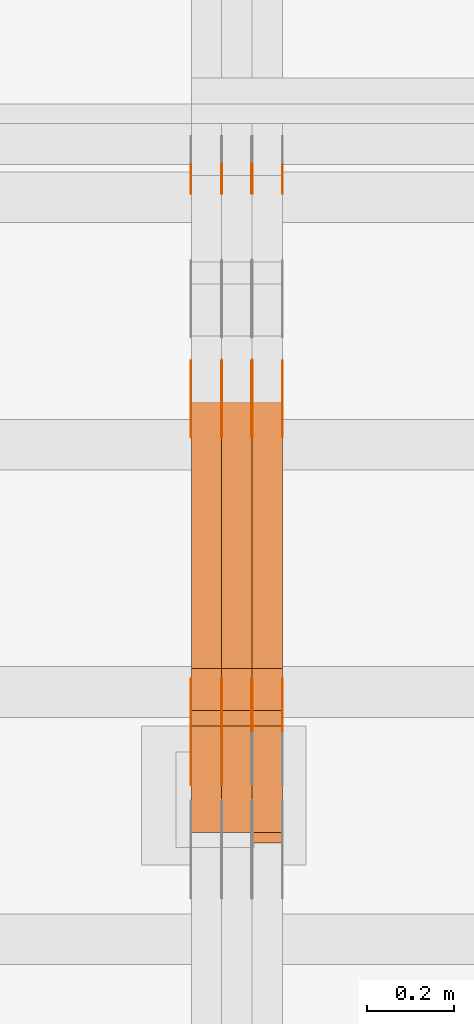
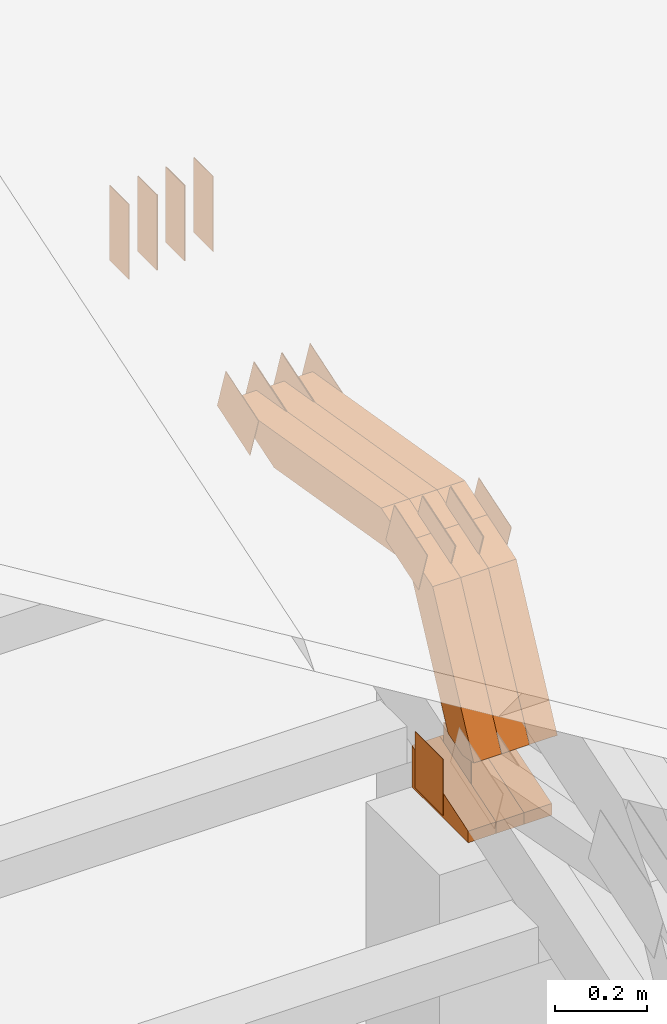
# One storey, part 278 of 385: 29 proxies.
"""IFC2X3 building model written with IfcOpenShell, lengths in millimetres."""

from ifc_helpers import new_model, entity, si_unit, converted_unit, derived_unit, direction, frame, frame_2d, origin, place, context, subcontext, project, spatial, polyline, rectangle, outline, extrude, source, transform, mapped, material, type_object, type_shapes, element, save


model = new_model("IFC2X3")

# Units and contexts
model_context = context("Model", 3, precision=0.01, world=origin(), true_north=direction((6.12303176911189e-17, 1.0)))
body_context = subcontext(model_context, "Body", "Model", "MODEL_VIEW")
ifc_project = project(units=[si_unit("LENGTHUNIT", "METRE", prefix="MILLI"), si_unit("AREAUNIT", "SQUARE_METRE"), si_unit("VOLUMEUNIT", "CUBIC_METRE"), converted_unit("PLANEANGLEUNIT", "DEGREE", entity("IfcRatioMeasure", 0.0174532925199433), si_unit("PLANEANGLEUNIT", "RADIAN"), dimensions=[0, 0, 0, 0, 0, 0, 0]), si_unit("MASSUNIT", "GRAM", prefix="KILO"), derived_unit("MASSDENSITYUNIT", [(si_unit("MASSUNIT", "GRAM", prefix="KILO"), 1), (si_unit("LENGTHUNIT", "METRE"), -3)]), si_unit("TIMEUNIT", "SECOND"), si_unit("FREQUENCYUNIT", "HERTZ"), si_unit("THERMODYNAMICTEMPERATUREUNIT", "DEGREE_CELSIUS"), derived_unit("THERMALTRANSMITTANCEUNIT", [(si_unit("MASSUNIT", "GRAM", prefix="KILO"), 1), (si_unit("THERMODYNAMICTEMPERATUREUNIT", "KELVIN"), -1), (si_unit("TIMEUNIT", "SECOND"), -3)]), derived_unit("VOLUMETRICFLOWRATEUNIT", [(si_unit("LENGTHUNIT", "METRE"), 3), (si_unit("TIMEUNIT", "SECOND"), -1)]), si_unit("ELECTRICCURRENTUNIT", "AMPERE"), si_unit("ELECTRICVOLTAGEUNIT", "VOLT"), si_unit("POWERUNIT", "WATT"), si_unit("FORCEUNIT", "NEWTON", prefix="KILO"), si_unit("ILLUMINANCEUNIT", "LUX"), si_unit("LUMINOUSFLUXUNIT", "LUMEN"), si_unit("LUMINOUSINTENSITYUNIT", "CANDELA"), derived_unit("USERDEFINED", [(si_unit("MASSUNIT", "GRAM", prefix="KILO"), -1), (si_unit("LENGTHUNIT", "METRE"), -2), (si_unit("TIMEUNIT", "SECOND"), 3), (si_unit("LUMINOUSFLUXUNIT", "LUMEN"), 1)]), derived_unit("LINEARVELOCITYUNIT", [(si_unit("LENGTHUNIT", "METRE"), 1), (si_unit("TIMEUNIT", "SECOND"), -1)]), si_unit("PRESSUREUNIT", "PASCAL"), derived_unit("USERDEFINED", [(si_unit("LENGTHUNIT", "METRE"), -2), (si_unit("MASSUNIT", "GRAM", prefix="KILO"), 1), (si_unit("TIMEUNIT", "SECOND"), -2)])], contexts=[model_context])

# Site, building, storey
site_placement = place(None, origin())
site = spatial("IfcSite", under=ifc_project, at=site_placement, CompositionType="ELEMENT")
building_placement = place(site_placement, origin())
building = spatial("IfcBuilding", under=site, at=building_placement, CompositionType="ELEMENT")
storey_placement = place(building_placement, origin())
storey = spatial("IfcBuildingStorey", under=building, at=storey_placement, Name="Default", CompositionType="ELEMENT", Elevation=0.0)

# Proxies
ifc_material_1 = material(Name="IfcSurfaceStyle #415732")
building_element_proxy_type_1 = type_object("IfcBuildingElementProxyType", PredefinedType="NOTDEFINED", material=ifc_material_1)
shared_shape_1 = source(origin(), body_context, "Body", "SweptSolid", [
    extrude(rectangle(XDim=200.0, YDim=84.0, at=frame_2d((0.0, -7.105427357601e-15), x_axis=(1.0, 0.0))), frame((100.0, 42.0, 0.0), z_axis=(0.0, 0.0, 1.0), x_axis=(-1.0, 0.0, 0.0)), (0.0, 0.0, 1.0), 1.3),
])
type_shapes(building_element_proxy_type_1, [shared_shape_1])
proxy_1_placement = place(building_placement, frame((33386.3, 13702.0, 3651.4150390625), z_axis=(-1.0, 0.0, 0.0), x_axis=(0.0, 0.0, -1.0)))
element("IfcBuildingElementProxy", 1, at=proxy_1_placement, inside=storey, type_object=building_element_proxy_type_1, material=ifc_material_1, context=body_context, shape_type="MappedRepresentation", body=[
    mapped(shared_shape_1, transform((0.0, 0.0, 0.0), scale=1.0)),
])
ifc_material_2 = material(Name="IfcSurfaceStyle #415675")
building_element_proxy_type_2 = type_object("IfcBuildingElementProxyType", PredefinedType="NOTDEFINED", material=ifc_material_2)
shared_shape_2 = source(origin(), body_context, "Body", "SweptSolid", [
    extrude(rectangle(XDim=200.0, YDim=84.0, at=frame_2d((0.0, -7.105427357601e-15), x_axis=(1.0, 0.0))), frame((100.0, 42.0, 0.0), z_axis=(0.0, 0.0, 1.0), x_axis=(-1.0, 0.0, 0.0)), (0.0, 0.0, 1.0), 1.3),
])
type_shapes(building_element_proxy_type_2, [shared_shape_2])
proxy_2_placement = place(building_placement, frame((33315.0, 13702.0, 3651.4150390625), z_axis=(-1.0, 0.0, 0.0), x_axis=(0.0, 0.0, -1.0)))
element("IfcBuildingElementProxy", 2, at=proxy_2_placement, inside=storey, type_object=building_element_proxy_type_2, material=ifc_material_2, context=body_context, shape_type="MappedRepresentation", body=[
    mapped(shared_shape_2, transform((0.0, 0.0, 0.0), scale=1.0)),
])
ifc_material_3 = material(Name="IfcSurfaceStyle #415618")
building_element_proxy_type_3 = type_object("IfcBuildingElementProxyType", PredefinedType="NOTDEFINED", material=ifc_material_3)
shared_shape_3 = source(origin(), body_context, "Body", "SweptSolid", [
    extrude(rectangle(XDim=200.0, YDim=84.0, at=frame_2d((0.0, -7.105427357601e-15), x_axis=(1.0, 0.0))), frame((100.0, 42.0, 0.0), z_axis=(0.0, 0.0, 1.0), x_axis=(-1.0, 0.0, 0.0)), (0.0, 0.0, 1.0), 1.3),
])
type_shapes(building_element_proxy_type_3, [shared_shape_3])
proxy_3_placement = place(building_placement, frame((33316.3, 13702.0, 3651.4150390625), z_axis=(-1.0, 0.0, 0.0), x_axis=(0.0, 0.0, -1.0)))
element("IfcBuildingElementProxy", 3, at=proxy_3_placement, inside=storey, type_object=building_element_proxy_type_3, material=ifc_material_3, context=body_context, shape_type="MappedRepresentation", body=[
    mapped(shared_shape_3, transform((0.0, 0.0, 0.0), scale=1.0)),
])
ifc_material_4 = material(Name="IfcSurfaceStyle #415561")
building_element_proxy_type_4 = type_object("IfcBuildingElementProxyType", PredefinedType="NOTDEFINED", material=ifc_material_4)
shared_shape_4 = source(origin(), body_context, "Body", "SweptSolid", [
    extrude(rectangle(XDim=200.0, YDim=84.0, at=frame_2d((0.0, -7.105427357601e-15), x_axis=(1.0, 0.0))), frame((100.0, 42.0, 0.0), z_axis=(0.0, 0.0, 1.0), x_axis=(-1.0, 0.0, 0.0)), (0.0, 0.0, 1.0), 1.29999999999998),
])
type_shapes(building_element_proxy_type_4, [shared_shape_4])
proxy_4_placement = place(building_placement, frame((33245.0, 13702.0, 3651.4150390625), z_axis=(-1.0, 0.0, 0.0), x_axis=(0.0, 0.0, -1.0)))
element("IfcBuildingElementProxy", 4, at=proxy_4_placement, inside=storey, type_object=building_element_proxy_type_4, material=ifc_material_4, context=body_context, shape_type="MappedRepresentation", body=[
    mapped(shared_shape_4, transform((0.0, 0.0, 0.0), scale=1.0)),
])
ifc_material_5 = material(Name="IfcSurfaceStyle #415504")
building_element_proxy_type_5 = type_object("IfcBuildingElementProxyType", PredefinedType="NOTDEFINED", material=ifc_material_5)
shared_shape_5 = source(origin(), body_context, "Body", "SweptSolid", [
    extrude(rectangle(XDim=200.0, YDim=84.0, at=frame_2d((0.0, -7.105427357601e-15), x_axis=(1.0, 0.0))), frame((100.0, 42.0, 0.0), z_axis=(0.0, 0.0, 1.0), x_axis=(-1.0, 0.0, 0.0)), (0.0, 0.0, 1.0), 1.29999999999998),
])
type_shapes(building_element_proxy_type_5, [shared_shape_5])
proxy_5_placement = place(building_placement, frame((33246.3, 13702.0, 3651.4150390625), z_axis=(-1.0, 0.0, 0.0), x_axis=(0.0, 0.0, -1.0)))
element("IfcBuildingElementProxy", 5, at=proxy_5_placement, inside=storey, type_object=building_element_proxy_type_5, material=ifc_material_5, context=body_context, shape_type="MappedRepresentation", body=[
    mapped(shared_shape_5, transform((0.0, 0.0, 0.0), scale=1.0)),
])
ifc_material_6 = material(Name="IfcSurfaceStyle #415447")
building_element_proxy_type_6 = type_object("IfcBuildingElementProxyType", PredefinedType="NOTDEFINED", material=ifc_material_6)
shared_shape_6 = source(origin(), body_context, "Body", "SweptSolid", [
    extrude(rectangle(XDim=200.0, YDim=84.0, at=frame_2d((0.0, -7.105427357601e-15), x_axis=(1.0, 0.0))), frame((100.0, 42.0, 0.0), z_axis=(0.0, 0.0, 1.0), x_axis=(-1.0, 0.0, 0.0)), (0.0, 0.0, 1.0), 1.29999999999999),
])
type_shapes(building_element_proxy_type_6, [shared_shape_6])
proxy_6_placement = place(building_placement, frame((33175.0, 13702.0, 3651.4150390625), z_axis=(-1.0, 0.0, 0.0), x_axis=(0.0, 0.0, -1.0)))
element("IfcBuildingElementProxy", 6, at=proxy_6_placement, inside=storey, type_object=building_element_proxy_type_6, material=ifc_material_6, context=body_context, shape_type="MappedRepresentation", body=[
    mapped(shared_shape_6, transform((0.0, 0.0, 0.0), scale=1.0)),
])
ifc_material_7 = material(Name="IfcSurfaceStyle #415390")
building_element_proxy_type_7 = type_object("IfcBuildingElementProxyType", PredefinedType="NOTDEFINED", material=ifc_material_7)
shared_shape_7 = source(origin(), body_context, "Body", "SweptSolid", [
    extrude(outline(polyline([(-75.0003398116828, -59.9998507501386), (75.0003249421766, -59.9998507501386), (75.0003398116837, 59.9998507501387), (-75.0003249421775, 59.9998507501387), (-75.0003398116828, -59.9998507501386)])), frame((75.0003398116837, 60.0000773549637, 0.0), z_axis=(0.0, 0.0, 1.0), x_axis=(-1.0, 0.0, 0.0)), (0.0, 0.0, 1.0), 1.3),
])
type_shapes(building_element_proxy_type_7, [shared_shape_7])
proxy_7_placement = place(building_placement, frame((33386.3, 13054.73046875, 3417.8388671875), z_axis=(-1.0, 0.0, 0.0), x_axis=(0.0, 0.951056516295124, 0.309016994375039)))
element("IfcBuildingElementProxy", 7, at=proxy_7_placement, inside=storey, type_object=building_element_proxy_type_7, material=ifc_material_7, context=body_context, shape_type="MappedRepresentation", body=[
    mapped(shared_shape_7, transform((0.0, 0.0, 0.0), scale=1.0)),
])
ifc_material_8 = material(Name="IfcSurfaceStyle #415333")
building_element_proxy_type_8 = type_object("IfcBuildingElementProxyType", PredefinedType="NOTDEFINED", material=ifc_material_8)
shared_shape_8 = source(origin(), body_context, "Body", "SweptSolid", [
    extrude(outline(polyline([(-75.0003398116828, -59.9998507501386), (75.0003249421766, -59.9998507501386), (75.0003398116837, 59.9998507501387), (-75.0003249421775, 59.9998507501387), (-75.0003398116828, -59.9998507501386)])), frame((75.0003398116837, 60.0000773549637, 0.0), z_axis=(0.0, 0.0, 1.0), x_axis=(-1.0, 0.0, 0.0)), (0.0, 0.0, 1.0), 1.3),
])
type_shapes(building_element_proxy_type_8, [shared_shape_8])
proxy_8_placement = place(building_placement, frame((33315.0, 13054.73046875, 3417.8388671875), z_axis=(-1.0, 0.0, 0.0), x_axis=(0.0, 0.951056516295124, 0.309016994375039)))
element("IfcBuildingElementProxy", 8, at=proxy_8_placement, inside=storey, type_object=building_element_proxy_type_8, material=ifc_material_8, context=body_context, shape_type="MappedRepresentation", body=[
    mapped(shared_shape_8, transform((0.0, 0.0, 0.0), scale=1.0)),
])
ifc_material_9 = material(Name="IfcSurfaceStyle #415276")
building_element_proxy_type_9 = type_object("IfcBuildingElementProxyType", PredefinedType="NOTDEFINED", material=ifc_material_9)
shared_shape_9 = source(origin(), body_context, "Body", "SweptSolid", [
    extrude(outline(polyline([(-75.0003398116828, -59.9998507501386), (75.0003249421766, -59.9998507501386), (75.0003398116837, 59.9998507501387), (-75.0003249421775, 59.9998507501387), (-75.0003398116828, -59.9998507501386)])), frame((75.0003398116837, 60.0000773549637, 0.0), z_axis=(0.0, 0.0, 1.0), x_axis=(-1.0, 0.0, 0.0)), (0.0, 0.0, 1.0), 1.3),
])
type_shapes(building_element_proxy_type_9, [shared_shape_9])
proxy_9_placement = place(building_placement, frame((33316.3, 13054.73046875, 3417.8388671875), z_axis=(-1.0, 0.0, 0.0), x_axis=(0.0, 0.951056516295124, 0.309016994375039)))
element("IfcBuildingElementProxy", 9, at=proxy_9_placement, inside=storey, type_object=building_element_proxy_type_9, material=ifc_material_9, context=body_context, shape_type="MappedRepresentation", body=[
    mapped(shared_shape_9, transform((0.0, 0.0, 0.0), scale=1.0)),
])
ifc_material_10 = material(Name="IfcSurfaceStyle #415219")
building_element_proxy_type_10 = type_object("IfcBuildingElementProxyType", PredefinedType="NOTDEFINED", material=ifc_material_10)
shared_shape_10 = source(origin(), body_context, "Body", "SweptSolid", [
    extrude(outline(polyline([(-75.0003398116828, -59.9998507501386), (75.0003249421766, -59.9998507501386), (75.0003398116837, 59.9998507501387), (-75.0003249421775, 59.9998507501387), (-75.0003398116828, -59.9998507501386)])), frame((75.0003398116837, 60.0000773549637, 0.0), z_axis=(0.0, 0.0, 1.0), x_axis=(-1.0, 0.0, 0.0)), (0.0, 0.0, 1.0), 1.29999999999999),
])
type_shapes(building_element_proxy_type_10, [shared_shape_10])
proxy_10_placement = place(building_placement, frame((33245.0, 13054.73046875, 3417.8388671875), z_axis=(-1.0, 0.0, 0.0), x_axis=(0.0, 0.951056516295124, 0.309016994375039)))
element("IfcBuildingElementProxy", 10, at=proxy_10_placement, inside=storey, type_object=building_element_proxy_type_10, material=ifc_material_10, context=body_context, shape_type="MappedRepresentation", body=[
    mapped(shared_shape_10, transform((0.0, 0.0, 0.0), scale=1.0)),
])
ifc_material_11 = material(Name="IfcSurfaceStyle #415162")
building_element_proxy_type_11 = type_object("IfcBuildingElementProxyType", PredefinedType="NOTDEFINED", material=ifc_material_11)
shared_shape_11 = source(origin(), body_context, "Body", "SweptSolid", [
    extrude(outline(polyline([(-75.0003398116828, -59.9998507501386), (75.0003249421766, -59.9998507501386), (75.0003398116837, 59.9998507501387), (-75.0003249421775, 59.9998507501387), (-75.0003398116828, -59.9998507501386)])), frame((75.0003398116837, 60.0000773549637, 0.0), z_axis=(0.0, 0.0, 1.0), x_axis=(-1.0, 0.0, 0.0)), (0.0, 0.0, 1.0), 1.29999999999999),
])
type_shapes(building_element_proxy_type_11, [shared_shape_11])
proxy_11_placement = place(building_placement, frame((33246.3, 13054.73046875, 3417.8388671875), z_axis=(-1.0, 0.0, 0.0), x_axis=(0.0, 0.951056516295124, 0.309016994375039)))
element("IfcBuildingElementProxy", 11, at=proxy_11_placement, inside=storey, type_object=building_element_proxy_type_11, material=ifc_material_11, context=body_context, shape_type="MappedRepresentation", body=[
    mapped(shared_shape_11, transform((0.0, 0.0, 0.0), scale=1.0)),
])
ifc_material_12 = material(Name="IfcSurfaceStyle #415105")
building_element_proxy_type_12 = type_object("IfcBuildingElementProxyType", PredefinedType="NOTDEFINED", material=ifc_material_12)
shared_shape_12 = source(origin(), body_context, "Body", "SweptSolid", [
    extrude(outline(polyline([(-75.0003398116828, -59.9998507501386), (75.0003249421766, -59.9998507501386), (75.0003398116837, 59.9998507501387), (-75.0003249421775, 59.9998507501387), (-75.0003398116828, -59.9998507501386)])), frame((75.0003398116837, 60.0000773549637, 0.0), z_axis=(0.0, 0.0, 1.0), x_axis=(-1.0, 0.0, 0.0)), (0.0, 0.0, 1.0), 1.29999999999999),
])
type_shapes(building_element_proxy_type_12, [shared_shape_12])
proxy_12_placement = place(building_placement, frame((33175.0, 13054.73046875, 3417.8388671875), z_axis=(-1.0, 0.0, 0.0), x_axis=(0.0, 0.951056516295124, 0.309016994375039)))
element("IfcBuildingElementProxy", 12, at=proxy_12_placement, inside=storey, type_object=building_element_proxy_type_12, material=ifc_material_12, context=body_context, shape_type="MappedRepresentation", body=[
    mapped(shared_shape_12, transform((0.0, 0.0, 0.0), scale=1.0)),
])
ifc_material_13 = material(Name="IfcSurfaceStyle #413110")
building_element_proxy_type_13 = type_object("IfcBuildingElementProxyType", PredefinedType="NOTDEFINED", material=ifc_material_13)
shared_shape_13 = source(origin(), body_context, "Body", "SweptSolid", [
    extrude(rectangle(XDim=150.0, YDim=119.999999999985, at=frame_2d((-7.105427357601e-15, 0.0), x_axis=(1.0, 0.0))), frame((75.0, 60.0, 0.0), z_axis=(0.0, 0.0, 1.0), x_axis=(-1.0, 0.0, 0.0)), (0.0, 0.0, 1.0), 1.29999999999999),
])
type_shapes(building_element_proxy_type_13, [shared_shape_13])
proxy_13_placement = place(building_placement, frame((33246.3, 12372.95703125, 3007.04687500001), z_axis=(-1.0, 0.0, 0.0), x_axis=(0.0, 0.0, -1.0)))
element("IfcBuildingElementProxy", 13, at=proxy_13_placement, inside=storey, type_object=building_element_proxy_type_13, material=ifc_material_13, context=body_context, shape_type="MappedRepresentation", body=[
    mapped(shared_shape_13, transform((0.0, 0.0, 0.0), scale=1.0)),
])
ifc_material_14 = material(Name="IfcSurfaceStyle #413053")
building_element_proxy_type_14 = type_object("IfcBuildingElementProxyType", PredefinedType="NOTDEFINED", material=ifc_material_14)
shared_shape_14 = source(origin(), body_context, "Body", "SweptSolid", [
    extrude(rectangle(XDim=150.0, YDim=119.999999999985, at=frame_2d((-7.105427357601e-15, 0.0), x_axis=(1.0, 0.0))), frame((75.0, 60.0, 0.0), z_axis=(0.0, 0.0, 1.0), x_axis=(-1.0, 0.0, 0.0)), (0.0, 0.0, 1.0), 1.29999999999999),
])
type_shapes(building_element_proxy_type_14, [shared_shape_14])
proxy_14_placement = place(building_placement, frame((33175.0, 12372.95703125, 3007.04687500001), z_axis=(-1.0, 0.0, 0.0), x_axis=(0.0, 0.0, -1.0)))
element("IfcBuildingElementProxy", 14, at=proxy_14_placement, inside=storey, type_object=building_element_proxy_type_14, material=ifc_material_14, context=body_context, shape_type="MappedRepresentation", body=[
    mapped(shared_shape_14, transform((0.0, 0.0, 0.0), scale=1.0)),
])
ifc_material_15 = material(Name="IfcSurfaceStyle #406156")
building_element_proxy_type_15 = type_object("IfcBuildingElementProxyType", PredefinedType="NOTDEFINED", material=ifc_material_15)
shared_shape_15 = source(origin(), body_context, "Body", "SweptSolid", [
    extrude(outline(polyline([(-74.9998754286244, -60.0000016373506), (74.9998605591063, -60.0000016373506), (74.9998754286244, 60.0000016373506), (-74.9998605591063, 60.0000016373506), (-74.9998754286244, -60.0000016373506)])), frame((74.9998754286244, 60.0000016373506, 0.0), z_axis=(0.0, 0.0, 1.0), x_axis=(-1.0, 0.0, 0.0)), (0.0, 0.0, 1.0), 1.3),
])
type_shapes(building_element_proxy_type_15, [shared_shape_15])
proxy_15_placement = place(building_placement, frame((33386.3, 12321.1620861463, 3506.17707344366), z_axis=(-1.0, 0.0, 0.0), x_axis=(0.0, 0.951056516295154, 0.309016994374948)))
element("IfcBuildingElementProxy", 15, at=proxy_15_placement, inside=storey, type_object=building_element_proxy_type_15, material=ifc_material_15, context=body_context, shape_type="MappedRepresentation", body=[
    mapped(shared_shape_15, transform((0.0, 0.0, 0.0), scale=1.0)),
])
ifc_material_16 = material(Name="IfcSurfaceStyle #406099")
building_element_proxy_type_16 = type_object("IfcBuildingElementProxyType", PredefinedType="NOTDEFINED", material=ifc_material_16)
shared_shape_16 = source(origin(), body_context, "Body", "SweptSolid", [
    extrude(outline(polyline([(-74.9998754286244, -60.0000016373506), (74.9998605591063, -60.0000016373506), (74.9998754286244, 60.0000016373506), (-74.9998605591063, 60.0000016373506), (-74.9998754286244, -60.0000016373506)])), frame((74.9998754286244, 60.0000016373506, 0.0), z_axis=(0.0, 0.0, 1.0), x_axis=(-1.0, 0.0, 0.0)), (0.0, 0.0, 1.0), 1.3),
])
type_shapes(building_element_proxy_type_16, [shared_shape_16])
proxy_16_placement = place(building_placement, frame((33315.0, 12321.1620861463, 3506.17707344366), z_axis=(-1.0, 0.0, 0.0), x_axis=(0.0, 0.951056516295154, 0.309016994374948)))
element("IfcBuildingElementProxy", 16, at=proxy_16_placement, inside=storey, type_object=building_element_proxy_type_16, material=ifc_material_16, context=body_context, shape_type="MappedRepresentation", body=[
    mapped(shared_shape_16, transform((0.0, 0.0, 0.0), scale=1.0)),
])
ifc_material_17 = material(Name="IfcSurfaceStyle #406042")
building_element_proxy_type_17 = type_object("IfcBuildingElementProxyType", PredefinedType="NOTDEFINED", material=ifc_material_17)
shared_shape_17 = source(origin(), body_context, "Body", "SweptSolid", [
    extrude(outline(polyline([(-74.9998754286244, -60.0000016373506), (74.9998605591063, -60.0000016373506), (74.9998754286244, 60.0000016373506), (-74.9998605591063, 60.0000016373506), (-74.9998754286244, -60.0000016373506)])), frame((74.9998754286244, 60.0000016373506, 0.0), z_axis=(0.0, 0.0, 1.0), x_axis=(-1.0, 0.0, 0.0)), (0.0, 0.0, 1.0), 1.3),
])
type_shapes(building_element_proxy_type_17, [shared_shape_17])
proxy_17_placement = place(building_placement, frame((33316.3, 12321.1620861463, 3506.17707344366), z_axis=(-1.0, 0.0, 0.0), x_axis=(0.0, 0.951056516295154, 0.309016994374948)))
element("IfcBuildingElementProxy", 17, at=proxy_17_placement, inside=storey, type_object=building_element_proxy_type_17, material=ifc_material_17, context=body_context, shape_type="MappedRepresentation", body=[
    mapped(shared_shape_17, transform((0.0, 0.0, 0.0), scale=1.0)),
])
ifc_material_18 = material(Name="IfcSurfaceStyle #405985")
building_element_proxy_type_18 = type_object("IfcBuildingElementProxyType", PredefinedType="NOTDEFINED", material=ifc_material_18)
shared_shape_18 = source(origin(), body_context, "Body", "SweptSolid", [
    extrude(outline(polyline([(-74.9998754286244, -60.0000016373506), (74.9998605591063, -60.0000016373506), (74.9998754286244, 60.0000016373506), (-74.9998605591063, 60.0000016373506), (-74.9998754286244, -60.0000016373506)])), frame((74.9998754286244, 60.0000016373506, 0.0), z_axis=(0.0, 0.0, 1.0), x_axis=(-1.0, 0.0, 0.0)), (0.0, 0.0, 1.0), 1.29999999999999),
])
type_shapes(building_element_proxy_type_18, [shared_shape_18])
proxy_18_placement = place(building_placement, frame((33245.0, 12321.1620861463, 3506.17707344366), z_axis=(-1.0, 0.0, 0.0), x_axis=(0.0, 0.951056516295154, 0.309016994374948)))
element("IfcBuildingElementProxy", 18, at=proxy_18_placement, inside=storey, type_object=building_element_proxy_type_18, material=ifc_material_18, context=body_context, shape_type="MappedRepresentation", body=[
    mapped(shared_shape_18, transform((0.0, 0.0, 0.0), scale=1.0)),
])
ifc_material_19 = material(Name="IfcSurfaceStyle #405928")
building_element_proxy_type_19 = type_object("IfcBuildingElementProxyType", PredefinedType="NOTDEFINED", material=ifc_material_19)
shared_shape_19 = source(origin(), body_context, "Body", "SweptSolid", [
    extrude(outline(polyline([(-74.9998754286244, -60.0000016373506), (74.9998605591063, -60.0000016373506), (74.9998754286244, 60.0000016373506), (-74.9998605591063, 60.0000016373506), (-74.9998754286244, -60.0000016373506)])), frame((74.9998754286244, 60.0000016373506, 0.0), z_axis=(0.0, 0.0, 1.0), x_axis=(-1.0, 0.0, 0.0)), (0.0, 0.0, 1.0), 1.29999999999999),
])
type_shapes(building_element_proxy_type_19, [shared_shape_19])
proxy_19_placement = place(building_placement, frame((33246.3, 12321.1620861463, 3506.17707344366), z_axis=(-1.0, 0.0, 0.0), x_axis=(0.0, 0.951056516295154, 0.309016994374948)))
element("IfcBuildingElementProxy", 19, at=proxy_19_placement, inside=storey, type_object=building_element_proxy_type_19, material=ifc_material_19, context=body_context, shape_type="MappedRepresentation", body=[
    mapped(shared_shape_19, transform((0.0, 0.0, 0.0), scale=1.0)),
])
ifc_material_20 = material(Name="IfcSurfaceStyle #405871")
building_element_proxy_type_20 = type_object("IfcBuildingElementProxyType", PredefinedType="NOTDEFINED", material=ifc_material_20)
shared_shape_20 = source(origin(), body_context, "Body", "SweptSolid", [
    extrude(outline(polyline([(-74.9998754286244, -60.0000016373506), (74.9998605591063, -60.0000016373506), (74.9998754286244, 60.0000016373506), (-74.9998605591063, 60.0000016373506), (-74.9998754286244, -60.0000016373506)])), frame((74.9998754286244, 60.0000016373506, 0.0), z_axis=(0.0, 0.0, 1.0), x_axis=(-1.0, 0.0, 0.0)), (0.0, 0.0, 1.0), 1.29999999999999),
])
type_shapes(building_element_proxy_type_20, [shared_shape_20])
proxy_20_placement = place(building_placement, frame((33175.0, 12321.1620861463, 3506.17707344366), z_axis=(-1.0, 0.0, 0.0), x_axis=(0.0, 0.951056516295154, 0.309016994374948)))
element("IfcBuildingElementProxy", 20, at=proxy_20_placement, inside=storey, type_object=building_element_proxy_type_20, material=ifc_material_20, context=body_context, shape_type="MappedRepresentation", body=[
    mapped(shared_shape_20, transform((0.0, 0.0, 0.0), scale=1.0)),
])
ifc_material_21 = material(Name="IfcSurfaceStyle #397696")
building_element_proxy_type_21 = type_object("IfcBuildingElementProxyType", Name="T1-E1 397694", PredefinedType="NOTDEFINED", material=ifc_material_21)
shared_shape_21 = source(origin(), body_context, "Body", "SweptSolid", [
    extrude(outline(polyline([(-75.1378173828004, -122.500000000005), (35.3350830078246, -122.500000000005), (35.3350830078004, 122.500000000005), (4.46765136717545, 122.500000000005), (-75.1378173828004, -122.500000000005)])), frame((35.3350830078246, 122.500000104877, 0.0), z_axis=(0.0, 0.0, 1.0), x_axis=(-1.0, 0.0, 0.0)), (0.0, 0.0, 1.0), 70.0),
])
type_shapes(building_element_proxy_type_21, [shared_shape_21])
proxy_21_placement = place(building_placement, frame((33385.0, 12145.0, 2849.54565429685), z_axis=(-1.0, 0.0, 0.0), x_axis=(0.0, 0.0, 1.0)))
element("IfcBuildingElementProxy", 21, at=proxy_21_placement, inside=storey, type_object=building_element_proxy_type_21, material=ifc_material_21, Name="T1-E1", context=body_context, shape_type="MappedRepresentation", body=[
    mapped(shared_shape_21, transform((0.0, 0.0, 0.0), scale=1.0)),
])
ifc_material_22 = material(Name="IfcSurfaceStyle #397639")
building_element_proxy_type_22 = type_object("IfcBuildingElementProxyType", Name="T1-E1 397637", PredefinedType="NOTDEFINED", material=ifc_material_22)
shared_shape_22 = source(origin(), body_context, "Body", "SweptSolid", [
    extrude(outline(polyline([(-75.1378173828004, -122.500000000005), (35.3350830078246, -122.500000000005), (35.3350830078004, 122.500000000005), (4.46765136717545, 122.500000000005), (-75.1378173828004, -122.500000000005)])), frame((35.3350830078246, 122.500000104877, 0.0), z_axis=(0.0, 0.0, 1.0), x_axis=(-1.0, 0.0, 0.0)), (0.0, 0.0, 1.0), 70.0),
])
type_shapes(building_element_proxy_type_22, [shared_shape_22])
proxy_22_placement = place(building_placement, frame((33315.0, 12145.0, 2849.54565429685), z_axis=(-1.0, 0.0, 0.0), x_axis=(0.0, 0.0, 1.0)))
element("IfcBuildingElementProxy", 22, at=proxy_22_placement, inside=storey, type_object=building_element_proxy_type_22, material=ifc_material_22, Name="T1-E1", context=body_context, shape_type="MappedRepresentation", body=[
    mapped(shared_shape_22, transform((0.0, 0.0, 0.0), scale=1.0)),
])
ifc_material_23 = material(Name="IfcSurfaceStyle #397582")
building_element_proxy_type_23 = type_object("IfcBuildingElementProxyType", Name="T1-E1 397580", PredefinedType="NOTDEFINED", material=ifc_material_23)
shared_shape_23 = source(origin(), body_context, "Body", "SweptSolid", [
    extrude(outline(polyline([(-75.1378173828004, -122.500000000005), (35.3350830078246, -122.500000000005), (35.3350830078004, 122.500000000005), (4.46765136717545, 122.500000000005), (-75.1378173828004, -122.500000000005)])), frame((35.3350830078246, 122.500000104877, 0.0), z_axis=(0.0, 0.0, 1.0), x_axis=(-1.0, 0.0, 0.0)), (0.0, 0.0, 1.0), 70.0),
])
type_shapes(building_element_proxy_type_23, [shared_shape_23])
proxy_23_placement = place(building_placement, frame((33245.0, 12145.0, 2849.54565429685), z_axis=(-1.0, 0.0, 0.0), x_axis=(0.0, 0.0, 1.0)))
element("IfcBuildingElementProxy", 23, at=proxy_23_placement, inside=storey, type_object=building_element_proxy_type_23, material=ifc_material_23, Name="T1-E1", context=body_context, shape_type="MappedRepresentation", body=[
    mapped(shared_shape_23, transform((0.0, 0.0, 0.0), scale=1.0)),
])
ifc_material_24 = material(Name="IfcSurfaceStyle #395968")
building_element_proxy_type_24 = type_object("IfcBuildingElementProxyType", Name="T1-W7 395966", PredefinedType="NOTDEFINED", material=ifc_material_24)
shared_shape_24 = source(origin(), body_context, "Body", "SweptSolid", [
    extrude(outline(polyline([(-296.174043820986, -47.5000676566704), (297.841254477443, -47.5000676566704), (283.518570346415, -7.10254316533821e-06), (192.674144473719, 47.500071207942), (-477.859925476591, 47.500071207942), (-296.174043820986, -47.5000676566704)])), frame((297.841254477443, 47.5000816097442, 0.0), z_axis=(0.0, 0.0, 1.0), x_axis=(-1.0, 0.0, 0.0)), (0.0, 0.0, 1.0), 70.0),
])
type_shapes(building_element_proxy_type_24, [shared_shape_24])
proxy_24_placement = place(building_placement, frame((33385.0, 12419.2991208897, 3526.2136755972), z_axis=(-1.0, 0.0, 0.0), x_axis=(0.0, 0.985983815111804, -0.166840991178939)))
element("IfcBuildingElementProxy", 24, at=proxy_24_placement, inside=storey, type_object=building_element_proxy_type_24, material=ifc_material_24, Name="T1-W7", context=body_context, shape_type="MappedRepresentation", body=[
    mapped(shared_shape_24, transform((0.0, 0.0, 0.0), scale=1.0)),
])
ifc_material_25 = material(Name="IfcSurfaceStyle #395902")
building_element_proxy_type_25 = type_object("IfcBuildingElementProxyType", Name="T1-W7 395900", PredefinedType="NOTDEFINED", material=ifc_material_25)
shared_shape_25 = source(origin(), body_context, "Body", "SweptSolid", [
    extrude(outline(polyline([(-296.174043820986, -47.5000676566704), (297.841254477443, -47.5000676566704), (283.518570346415, -7.10254316533821e-06), (192.674144473719, 47.500071207942), (-477.859925476591, 47.500071207942), (-296.174043820986, -47.5000676566704)])), frame((297.841254477443, 47.5000816097442, 0.0), z_axis=(0.0, 0.0, 1.0), x_axis=(-1.0, 0.0, 0.0)), (0.0, 0.0, 1.0), 70.0),
])
type_shapes(building_element_proxy_type_25, [shared_shape_25])
proxy_25_placement = place(building_placement, frame((33315.0, 12419.2991208897, 3526.2136755972), z_axis=(-1.0, 0.0, 0.0), x_axis=(0.0, 0.985983815111804, -0.166840991178939)))
element("IfcBuildingElementProxy", 25, at=proxy_25_placement, inside=storey, type_object=building_element_proxy_type_25, material=ifc_material_25, Name="T1-W7", context=body_context, shape_type="MappedRepresentation", body=[
    mapped(shared_shape_25, transform((0.0, 0.0, 0.0), scale=1.0)),
])
ifc_material_26 = material(Name="IfcSurfaceStyle #395836")
building_element_proxy_type_26 = type_object("IfcBuildingElementProxyType", Name="T1-W7 395834", PredefinedType="NOTDEFINED", material=ifc_material_26)
shared_shape_26 = source(origin(), body_context, "Body", "SweptSolid", [
    extrude(outline(polyline([(-296.174043820986, -47.5000676566704), (297.841254477443, -47.5000676566704), (283.518570346415, -7.10254316533821e-06), (192.674144473719, 47.500071207942), (-477.859925476591, 47.500071207942), (-296.174043820986, -47.5000676566704)])), frame((297.841254477443, 47.5000816097442, 0.0), z_axis=(0.0, 0.0, 1.0), x_axis=(-1.0, 0.0, 0.0)), (0.0, 0.0, 1.0), 70.0),
])
type_shapes(building_element_proxy_type_26, [shared_shape_26])
proxy_26_placement = place(building_placement, frame((33245.0, 12419.2991208897, 3526.2136755972), z_axis=(-1.0, 0.0, 0.0), x_axis=(0.0, 0.985983815111804, -0.166840991178939)))
element("IfcBuildingElementProxy", 26, at=proxy_26_placement, inside=storey, type_object=building_element_proxy_type_26, material=ifc_material_26, Name="T1-W7", context=body_context, shape_type="MappedRepresentation", body=[
    mapped(shared_shape_26, transform((0.0, 0.0, 0.0), scale=1.0)),
])
ifc_material_27 = material(Name="IfcSurfaceStyle #395572")
building_element_proxy_type_27 = type_object("IfcBuildingElementProxyType", Name="T1-W36 395570", PredefinedType="NOTDEFINED", material=ifc_material_27)
shared_shape_27 = source(origin(), body_context, "Body", "SweptSolid", [
    extrude(outline(polyline([(-300.714670922549, -47.4998881108849), (134.031527004269, -47.499888110885), (180.52054953879, -0.000136170977331764), (193.89900152221, 47.500563476126), (-207.736407142719, 47.4993489166213), (-300.714670922549, -47.4998881108849)])), frame((193.899145164686, 47.5001861375837, 0.0), z_axis=(0.0, 0.0, 1.0), x_axis=(-1.0, 3.02403492980632e-06, 0.0)), (0.0, 0.0, 1.0), 70.0),
])
type_shapes(building_element_proxy_type_27, [shared_shape_27])
proxy_27_placement = place(building_placement, frame((33385.0, 12120.5935627532, 3076.1128858536), z_axis=(-1.0, 0.0, 0.0), x_axis=(0.0, 0.444384650266842, 0.895836080210669)))
element("IfcBuildingElementProxy", 27, at=proxy_27_placement, inside=storey, type_object=building_element_proxy_type_27, material=ifc_material_27, Name="T1-W36", context=body_context, shape_type="MappedRepresentation", body=[
    mapped(shared_shape_27, transform((0.0, 0.0, 0.0), scale=1.0)),
])
ifc_material_28 = material(Name="IfcSurfaceStyle #395506")
building_element_proxy_type_28 = type_object("IfcBuildingElementProxyType", Name="T1-W36 395504", PredefinedType="NOTDEFINED", material=ifc_material_28)
shared_shape_28 = source(origin(), body_context, "Body", "SweptSolid", [
    extrude(outline(polyline([(-300.714670922549, -47.4998881108849), (134.031527004269, -47.499888110885), (180.52054953879, -0.000136170977331764), (193.89900152221, 47.500563476126), (-207.736407142719, 47.4993489166213), (-300.714670922549, -47.4998881108849)])), frame((193.899145164686, 47.5001861375837, 0.0), z_axis=(0.0, 0.0, 1.0), x_axis=(-1.0, 3.02403492980632e-06, 0.0)), (0.0, 0.0, 1.0), 70.0),
])
type_shapes(building_element_proxy_type_28, [shared_shape_28])
proxy_28_placement = place(building_placement, frame((33315.0, 12120.5935627532, 3076.1128858536), z_axis=(-1.0, 0.0, 0.0), x_axis=(0.0, 0.444384650266842, 0.895836080210669)))
element("IfcBuildingElementProxy", 28, at=proxy_28_placement, inside=storey, type_object=building_element_proxy_type_28, material=ifc_material_28, Name="T1-W36", context=body_context, shape_type="MappedRepresentation", body=[
    mapped(shared_shape_28, transform((0.0, 0.0, 0.0), scale=1.0)),
])
ifc_material_29 = material(Name="IfcSurfaceStyle #395440")
building_element_proxy_type_29 = type_object("IfcBuildingElementProxyType", Name="T1-W36 395438", PredefinedType="NOTDEFINED", material=ifc_material_29)
shared_shape_29 = source(origin(), body_context, "Body", "SweptSolid", [
    extrude(outline(polyline([(-300.714670922549, -47.4998881108849), (134.031527004269, -47.499888110885), (180.52054953879, -0.000136170977331764), (193.89900152221, 47.500563476126), (-207.736407142719, 47.4993489166213), (-300.714670922549, -47.4998881108849)])), frame((193.899145164686, 47.5001861375837, 0.0), z_axis=(0.0, 0.0, 1.0), x_axis=(-1.0, 3.02403492980632e-06, 0.0)), (0.0, 0.0, 1.0), 70.0),
])
type_shapes(building_element_proxy_type_29, [shared_shape_29])
proxy_29_placement = place(building_placement, frame((33245.0, 12120.5935627532, 3076.1128858536), z_axis=(-1.0, 0.0, 0.0), x_axis=(0.0, 0.444384650266842, 0.895836080210669)))
element("IfcBuildingElementProxy", 29, at=proxy_29_placement, inside=storey, type_object=building_element_proxy_type_29, material=ifc_material_29, Name="T1-W36", context=body_context, shape_type="MappedRepresentation", body=[
    mapped(shared_shape_29, transform((0.0, 0.0, 0.0), scale=1.0)),
])

save(model, "model.ifc")
